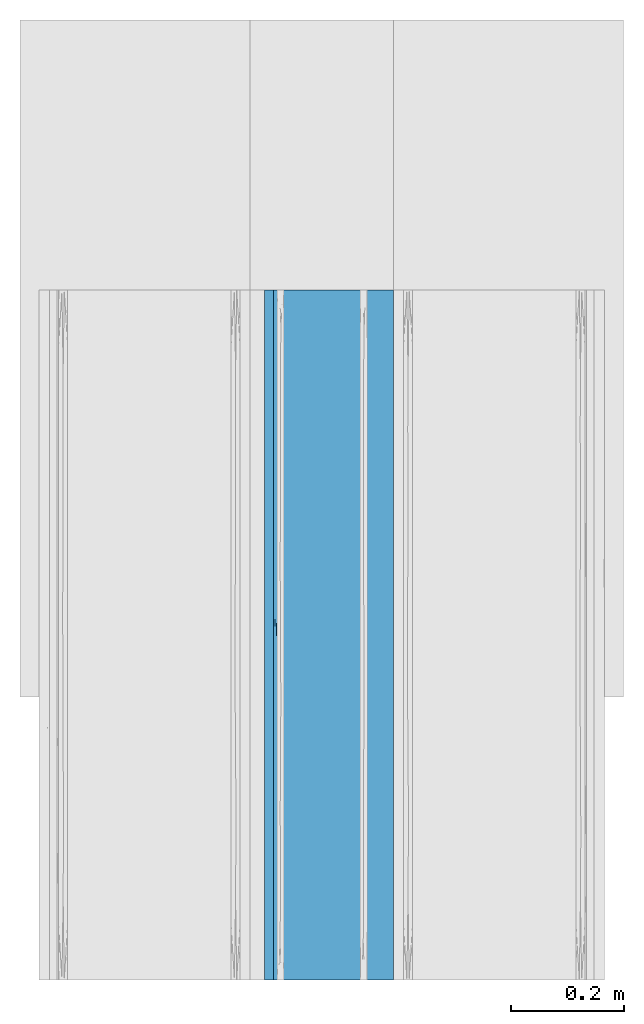
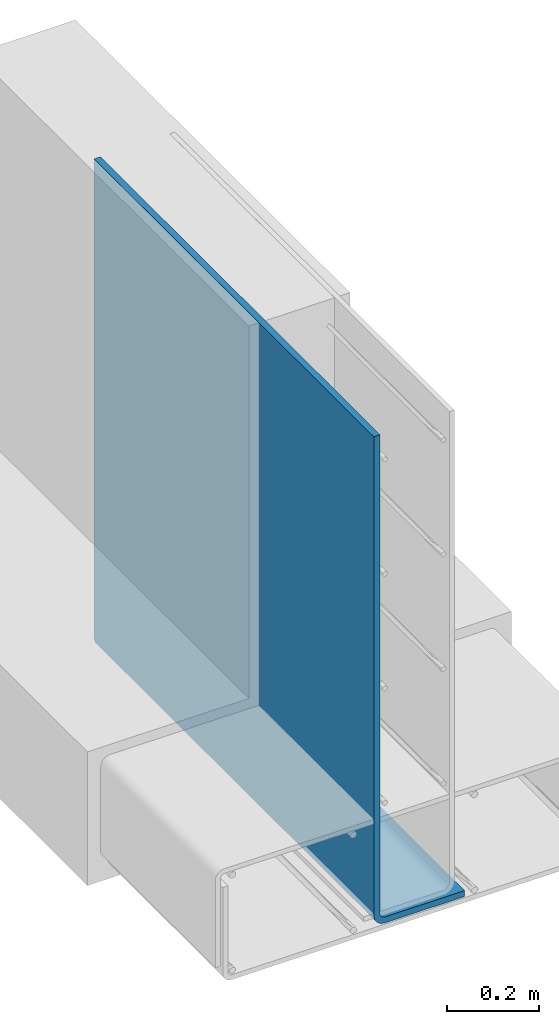
# One storey, part 2 of 10: 1 wall.
"""IFC2X3 building model written with IfcOpenShell, lengths in feet."""

from ifc_helpers import new_model, entity, si_unit, converted_unit, derived_unit, direction, frame, origin, place, context, subcontext, project, spatial, faceted_brep, material, type_object, element, save


model = new_model("IFC2X3")

# Units and contexts
model_context = context("Model", 3, precision=0.0001, world=origin(), true_north=direction((6.12303176911189e-17, 1.0)))
body_context = subcontext(model_context, "Body", "Model", "MODEL_VIEW")
ifc_project = project(units=[converted_unit("LENGTHUNIT", "FOOT", entity("IfcRatioMeasure", 0.3048), si_unit("LENGTHUNIT", "METRE"), dimensions=[1, 0, 0, 0, 0, 0, 0]), converted_unit("AREAUNIT", "SQUARE FOOT", entity("IfcRatioMeasure", 0.09290304), si_unit("AREAUNIT", "SQUARE_METRE"), dimensions=[2, 0, 0, 0, 0, 0, 0]), converted_unit("VOLUMEUNIT", "CUBIC FOOT", entity("IfcRatioMeasure", 0.028316846592), si_unit("VOLUMEUNIT", "CUBIC_METRE"), dimensions=[3, 0, 0, 0, 0, 0, 0]), converted_unit("PLANEANGLEUNIT", "DEGREE", entity("IfcRatioMeasure", 0.0174532925199433), si_unit("PLANEANGLEUNIT", "RADIAN"), dimensions=[0, 0, 0, 0, 0, 0, 0]), si_unit("MASSUNIT", "GRAM", prefix="KILO"), derived_unit("MASSDENSITYUNIT", [(si_unit("MASSUNIT", "GRAM", prefix="KILO"), 1), (si_unit("LENGTHUNIT", "METRE"), -3)]), si_unit("TIMEUNIT", "SECOND"), si_unit("FREQUENCYUNIT", "HERTZ"), si_unit("THERMODYNAMICTEMPERATUREUNIT", "DEGREE_CELSIUS"), derived_unit("THERMALTRANSMITTANCEUNIT", [(si_unit("MASSUNIT", "GRAM", prefix="KILO"), 1), (si_unit("THERMODYNAMICTEMPERATUREUNIT", "KELVIN"), -1), (si_unit("TIMEUNIT", "SECOND"), -3)]), derived_unit("VOLUMETRICFLOWRATEUNIT", [(si_unit("LENGTHUNIT", "METRE"), 3), (si_unit("TIMEUNIT", "SECOND"), -1)]), si_unit("ELECTRICCURRENTUNIT", "AMPERE"), si_unit("ELECTRICVOLTAGEUNIT", "VOLT"), si_unit("POWERUNIT", "WATT"), si_unit("FORCEUNIT", "NEWTON", prefix="KILO"), si_unit("ILLUMINANCEUNIT", "LUX"), si_unit("LUMINOUSFLUXUNIT", "LUMEN"), si_unit("LUMINOUSINTENSITYUNIT", "CANDELA"), derived_unit("USERDEFINED", [(si_unit("MASSUNIT", "GRAM", prefix="KILO"), -1), (si_unit("LENGTHUNIT", "METRE"), -2), (si_unit("TIMEUNIT", "SECOND"), 3), (si_unit("LUMINOUSFLUXUNIT", "LUMEN"), 1)]), derived_unit("LINEARVELOCITYUNIT", [(si_unit("LENGTHUNIT", "METRE"), 1), (si_unit("TIMEUNIT", "SECOND"), -1)]), si_unit("PRESSUREUNIT", "PASCAL"), derived_unit("USERDEFINED", [(si_unit("LENGTHUNIT", "METRE"), -2), (si_unit("MASSUNIT", "GRAM", prefix="KILO"), 1), (si_unit("TIMEUNIT", "SECOND"), -2)])], contexts=[model_context])

# Site, building, storey
site_placement = place(None, origin())
site = spatial("IfcSite", under=ifc_project, at=site_placement, CompositionType="ELEMENT")
building_placement = place(site_placement, origin())
building = spatial("IfcBuilding", under=site, at=building_placement, CompositionType="ELEMENT")
storey_placement = place(building_placement, frame((0.0, 0.0, 11.2604166666667)))
storey = spatial("IfcBuildingStorey", under=building, at=storey_placement, Name="2ND FLOOR", CompositionType="ELEMENT", Elevation=11.2604166666667)

# Wall
ifc_material = material()
wall_type = type_object("IfcWallType", Name="Generic Models 1", PredefinedType="NOTDEFINED", material=ifc_material)
wall_placement = place(storey_placement, frame((1429.34545536655, 0.249999999995818, 2.87899174408165), z_axis=(0.0, 0.0, 1.0), x_axis=(0.0, 1.0, 0.0)))
element("IfcWall", 1, at=wall_placement, inside=storey, type_object=wall_type, material=ifc_material, Name="Generic Models 48:Generic Models 1", ObjectType="Generic Models 48:Generic Models 1", context=body_context, shape_type="Brep", body=[
    faceted_brep([(4.0, -0.0839364688906699, 0.0535477115896743), (4.0, -0.0950595260521823, 0.05208333333354), (4.0, -0.750000000000227, 0.052083333333341), (4.0, -0.750000000000227, 0.0), (4.0, -0.0950595260521823, 0.0), (4.0, -0.0704563102915472, 0.00323907480378516), (4.0, -0.0475297630262048, 0.0127355616194791), (4.0, -0.027842290564422, 0.027842290564486), (4.0, -0.0127355616193654, 0.0475297630262546), (4.0, -0.00323907480355956, 0.0704563102916005), (4.0, 0.0, 0.0950595260523031), (4.0, 0.0, 4.27604166666677), (4.0, -0.0520833333332575, 4.27604166666677), (4.0, -0.0520833333334849, 0.0950595260523031), (4.0, -0.0535477115895446, 0.0839364688906912), (4.0, -0.0578410513996914, 0.0735714296929206), (4.0, -0.064670768751057, 0.0646707687512862), (4.0, -0.0735714296927199, 0.0578410513999188), (0.0, -0.0520833333332575, 0.095059526052296), (0.0, -0.0520833333332575, 4.27604166666676), (0.0, 0.0, 4.27604166666676), (0.0, 0.0, 0.095059526052296), (0.0, -0.00323907480355956, 0.0704563102915934), (0.0, -0.0127355616193654, 0.0475297630262475), (0.0, -0.027842290564422, 0.0278422905644788), (0.0, -0.0475297630262048, 0.012735561619472), (0.0, -0.0704563102915472, 0.00323907480377805), (0.0, -0.0950595260521823, 0.0), (0.0, -0.750000000000227, 0.0), (0.0, -0.750000000000227, 0.0520833333333339), (0.0, -0.0950595260521823, 0.0520833333335329), (0.0, -0.0839364688906699, 0.0535477115896672), (0.0, -0.0735714296927199, 0.0578410513999117), (0.0, -0.064670768751057, 0.0646707687512791), (0.0, -0.0578410513996914, 0.0735714296929135), (0.0, -0.0535477115895446, 0.0839364688906841), (3.38335830863443, 0.0, 0.0950595260523013), (2.76672867777641, 0.0, 0.0950595260522995), (2.1500990469184, 0.0, 0.0950595260522995), (1.53345735555282, 0.0, 0.0950595260522995), (0.766734708030195, 0.0, 0.095059526052296), (3.50726805026842, -0.0586818203451003, 0.00723597556192601), (3.27393777511601, -0.0371909531336314, 0.0196437335310033), (1.78353021472899, -0.00784005269451882, 0.0572563917847315), (2.14117387238675, -0.0196437335334849, 0.0371909531302208), (1.43361804854268, -0.0178613728260189, 0.0395909887384924), (3.37133042434599, -0.0196437335334849, 0.0371909531301888), (3.4751662918405, -0.00478311583447066, 0.0652856574515912), (1.1606637191544, -0.0371909531506844, 0.0196437335178299), (1.64315400905003, -0.0461789340974974, 0.0135303826530766), (1.27449515240186, -0.0633988724214305, 0.00542740845533274), (3.23328222667768, -0.0950595260521823, 0.0), (3.20256950666254, -0.0750628849159511, 0.00212703530490899), (3.07504825111212, -0.00157360909474846, 0.0778346363906177), (2.27636655169743, -0.00264474021491878, 0.0727924909575339), (0.91445812895005, -0.00186893853992842, 0.076302450257959), (0.924951748368481, -0.0775154033924537, 0.001632992062504), (0.616621456932823, -0.0950595260521823, 0.0), (2.8978709629844, -0.0586818203457824, 0.00723597556160094), (0.726062224839728, -0.0196437335423525, 0.0371909531186834), (1.47536976743383, -0.00227903482004876, 0.0743690949317362), (0.524941123404908, -0.0371909531409074, 0.0196437335254522), (0.523544479057695, -0.00603105418076666, 0.061739191577983), (2.7562521483547, -0.018206365116157, 0.0391139708455643), (2.46098355568912, -0.038044837346888, 0.0189961395572578), (2.96682787508407, -0.0072359755636171, 0.0586818203408814), (0.7465040680103, -0.0586818203571511, 0.00723597555691313), (1.23328222667768, -0.0950595260521823, 0.0), (1.72599254399019, -0.0304074615403351, 0.0253714779550513), (2.61939838635962, -0.0756580354102425, 0.00200096570387309), (1.82218751554797, -0.0633150724090683, 0.00545705311681566), (1.8499036836105, -0.0950595260521823, 0.0), (1.10212903717549, -0.00723597557271205, 0.058681820319002), (2.37080233258585, -0.00956508641502296, 0.0535021646782798), (2.35548845504497, -0.0598832576645236, 0.00674789807741227), (2.46652514054331, -0.0950595260521823, 0.0), (3.58538628570743, -0.0950595260521823, 0.05208333333354), (3.17077257141486, -0.0950595260521823, 0.0520833333335382), (2.87807960507063, -0.0950595260521823, 0.0520833333335382), (2.5853866387264, -0.0950595260521823, 0.0520833333335382), (2.29269296634424, -0.0950595260521823, 0.0520833333335382), (2.0, -0.0950595260521823, 0.0520833333335364), (1.70730703365578, -0.0950595260521823, 0.0520833333335382), (1.41461336127362, -0.0950595260521823, 0.0520833333335347), (1.12192039492938, -0.0950595260521823, 0.0520833333335364), (0.829227428585153, -0.0950595260521823, 0.0520833333335347), (0.414613714292581, -0.0950595260524096, 0.0520833333335329), (0.343508341855533, -0.06096421998609, 0.0688972775850552), (0.24642137997777, -0.0553547012057152, 0.0786132491327418), (2.95385912061898, -0.0671572125691, 0.0623729226361025), (2.74421780120822, -0.0756354022480537, 0.0567234261587952), (3.09787157995616, -0.0779605053130581, 0.0556314062598702), (0.257111616052899, -0.0872671962911227, 0.052795679356878), (2.52465034980815, -0.0790851264434878, 0.0551625124079091), (2.33368133182246, -0.0735031881267787, 0.0578805341906605), (2.29269299774973, -0.081677182318117, 0.0542200106684696), (0.346070907250912, -0.0786132490784439, 0.0553547012283602), (2.73173249481835, -0.0856930366287543, 0.0531164453776292), (2.48423128693805, -0.0871304496311041, 0.0528211206881188), (0.4997990553644, -0.0528710843739191, 0.0868687672740833), (0.248516744073481, -0.052728189989466, 0.0876425773712306), (3.80586512939922, -0.0553547012129911, 0.0786132491152109), (3.74780526621007, -0.0527566628134082, 0.0874818679445095), (3.58538581327789, -0.0520833333334849, 0.0950595260523013), (3.49313826499759, -0.0528751288923104, 0.0868479624460363), (0.414614186722129, -0.0520833333334849, 0.0950595260522977), (3.65649165725621, -0.068897277555152, 0.0609642200091614), (3.71348541599941, -0.0609642200031431, 0.0688972775628098), (3.30751289932597, -0.0691599293538729, 0.060764278109378), (3.45927734759776, -0.0594241450330628, 0.0710371872773639), (3.20506927914898, -0.0609642200013241, 0.0688972775652505), (3.75357861923602, -0.0786132491082299, 0.0553547012159452), (0.250219458519215, -0.0688972775394632, 0.0609642200212246), (2.89455993463712, -0.0599559398117435, 0.0702665558055084), (3.75148325519992, -0.0876425773483334, 0.0527281899934824), (3.10938631631815, -0.0544012868585924, 0.0811361383081515), (0.54431608530737, -0.0856559896490126, 0.053124735678276), (1.11334942453932, -0.0549875058245561, 0.0795293510541804), (1.45114901067811, -0.055454032351463, 0.0783754615197712), (1.41892933789295, -0.0527407089648477, 0.0875714781808323), (3.52808113600233, -0.0876043389177994, 0.0527349076205557), (0.541386240932319, -0.0553547011959381, 0.0786132491562626), (0.805493389358163, -0.0534599123263888, 0.0842694714436831), (0.732200476778303, -0.0628856438781895, 0.0665675193408237), (3.33830627388194, -0.0543801832284316, 0.081197916909483), (1.95828153209831, -0.0552608766715821, 0.0788416147168505), (2.22557450496979, -0.0543799459010188, 0.0811986134085618), (1.9606536364037, -0.0528456510983233, 0.0870008721962403), (1.56096050227781, -0.0851551220914644, 0.0532402012994471), (0.57662606195596, -0.0760418240306535, 0.0565201935409547), (0.548364641454425, -0.0688972775158163, 0.0609642200392031), (3.02442549301749, -0.0868657433179578, 0.0528716715784903), (1.73105420255024, -0.0535178232776161, 0.0840486191331156), (3.45861375743398, -0.078613249105274, 0.0553547012172491), (3.30695394079733, -0.086519455238431, 0.0529404053219817), (3.55294395442797, -0.0553547012120816, 0.0786132491174563), (0.808282176293639, -0.0571481321976535, 0.0748189885939929), (0.975732396537778, -0.0702672708400769, 0.059955434807863), (0.975574506197251, -0.0869005017987092, 0.0528649355953252), (0.784056237130786, -0.0801656860983258, 0.0547466661683131), (1.22270559805292, -0.0815297955959977, 0.0542686013951901), (1.00727074968171, -0.0795123348625566, 0.0549941047177551), (1.7073070019562, -0.0757839476964364, 0.0566485221647639), (1.45058811261653, -0.0773733066776003, 0.0558912891142391), (1.88559123638505, -0.0846079880495836, 0.0533735752537208), (2.08573983713143, -0.0710323456626156, 0.0594274093158216), (1.74470681603436, -0.0653764161586423, 0.0639811392272449), (2.66861517219364, -0.0561484930942697, 0.0768143991756585), (2.50498577391431, -0.0646618362679874, 0.0646797038609428), (2.60365350016018, -0.0529044639536096, 0.0866986720253351), (2.87766484896829, -0.0530354350771631, 0.0860634759016108), (2.70847635885235, -0.068417706891978, 0.0613376249725981), (2.46068863060826, -0.0546557652439787, 0.080414074432154), (2.41461418672213, -0.0520833333334849, 0.0950595260522995), (2.03653500690591, -0.0610243254272973, 0.0688191324001401), (2.38388321984759, -0.0584062206412455, 0.0726209801310684), (0.829228373444251, -0.0520833333334849, 0.095059526052296), (1.03653667025295, -0.0520833333334849, 0.0950595260522977), (1.01938636295128, -0.0609642199488007, 0.06889727763377), (1.14018850857098, -0.0527474492546389, 0.0875334847507396), (1.48724211501289, -0.0602209726457659, 0.0698954974172068), (1.40042308287624, -0.0664782840467524, 0.0629648887117344), (1.24384256016637, -0.0520833333334849, 0.0950595260522977), (1.25767826442176, -0.0618047567277245, 0.0678368616387957), (1.17376868854571, -0.0669068622153191, 0.0625882978726953), (1.74354393160202, -0.0579399859857404, 0.0734009737954722), (1.22276049636679, -0.0731446832442089, 0.0580907175063849), (2.8938170462308, -0.055424927612421, 0.0784447209940442), (3.17077162655576, -0.0520833333334849, 0.0950595260523031), (2.79269411008658, -0.0520833333337123, 0.0950595260523031), (1.65845674688849, -0.0520833333334849, 0.0950595260522995), (2.03653426335767, -0.0520833333332575, 0.0950595260522995), (2.2377648516676, -0.0651019592553439, 0.0642456114645995)], [[[0, 1, 2, 3, 4, 5, 6, 7, 8, 9, 10, 11, 12, 13, 14, 15, 16, 17]], [[18, 19, 20, 21, 22, 23, 24, 25, 26, 27, 28, 29, 30, 31, 32, 33, 34, 35]], [[20, 19, 12, 11]], [[21, 20, 11, 10, 36, 37, 38, 39, 40]], [[41, 42, 6]], [[43, 44, 45]], [[6, 42, 7]], [[6, 5, 41]], [[46, 8, 7]], [[8, 46, 47]], [[48, 49, 50]], [[51, 52, 4]], [[22, 21, 40]], [[36, 10, 9]], [[37, 53, 54]], [[39, 55, 40]], [[26, 56, 57]], [[52, 58, 41]], [[45, 48, 59]], [[60, 38, 54]], [[24, 61, 25]], [[59, 23, 62]], [[44, 63, 64]], [[53, 47, 65]], [[56, 26, 66]], [[25, 61, 66]], [[46, 7, 42]], [[25, 66, 26]], [[55, 62, 22]], [[50, 67, 56]], [[23, 59, 24]], [[68, 48, 45]], [[36, 53, 37]], [[69, 58, 52]], [[70, 71, 50]], [[45, 59, 72]], [[55, 39, 60]], [[61, 59, 48]], [[64, 42, 58]], [[51, 69, 52]], [[44, 73, 63]], [[69, 74, 58]], [[68, 49, 48]], [[42, 64, 63]], [[47, 46, 65]], [[57, 56, 67]], [[57, 27, 26]], [[50, 56, 66]], [[47, 36, 9]], [[54, 53, 65]], [[43, 73, 44]], [[54, 43, 60]], [[36, 47, 53]], [[8, 47, 9]], [[48, 50, 66]], [[69, 71, 70]], [[59, 61, 24]], [[66, 61, 48]], [[42, 41, 58]], [[43, 45, 72]], [[45, 44, 68]], [[60, 43, 72]], [[43, 54, 73]], [[60, 72, 55]], [[62, 55, 72]], [[22, 40, 55]], [[59, 62, 72]], [[23, 22, 62]], [[54, 65, 73]], [[63, 65, 46]], [[65, 63, 73]], [[63, 46, 42]], [[44, 64, 68]], [[64, 74, 49]], [[64, 49, 68]], [[50, 49, 70]], [[5, 4, 52]], [[5, 52, 41]], [[69, 51, 75, 71]], [[38, 60, 39]], [[74, 69, 70]], [[49, 74, 70]], [[64, 58, 74]], [[67, 50, 71]], [[38, 37, 54]], [[28, 27, 57, 67, 71, 75, 51, 4, 3]], [[29, 28, 3, 2]], [[29, 2, 1, 76, 77, 78, 79, 80, 81, 82, 83, 84, 85, 86, 30]], [[34, 87, 88]], [[89, 90, 91]], [[92, 31, 30]], [[93, 94, 95]], [[33, 87, 34]], [[32, 31, 96]], [[97, 93, 98]], [[99, 100, 88]], [[14, 101, 15]], [[102, 103, 104]], [[105, 18, 100]], [[16, 106, 17]], [[107, 16, 15]], [[108, 109, 110]], [[106, 111, 17]], [[111, 0, 17]], [[89, 108, 110]], [[35, 34, 88]], [[32, 112, 33]], [[113, 89, 110]], [[16, 107, 106]], [[114, 76, 1]], [[115, 113, 110]], [[86, 85, 116]], [[117, 118, 119]], [[120, 114, 111]], [[99, 121, 122]], [[123, 121, 87]], [[115, 110, 124]], [[102, 101, 14]], [[96, 112, 32]], [[96, 92, 116]], [[125, 126, 127]], [[82, 128, 83]], [[129, 130, 96]], [[96, 31, 92]], [[131, 91, 97]], [[119, 118, 132]], [[133, 106, 108]], [[77, 76, 134]], [[135, 109, 107]], [[123, 136, 121]], [[121, 99, 88]], [[130, 87, 112]], [[123, 130, 137]], [[85, 84, 138]], [[129, 139, 137]], [[140, 141, 138]], [[128, 142, 143]], [[109, 108, 106]], [[13, 102, 14]], [[135, 107, 101]], [[121, 88, 87]], [[33, 112, 87]], [[130, 112, 96]], [[133, 111, 106]], [[133, 108, 91]], [[89, 91, 108]], [[134, 131, 77]], [[78, 77, 131]], [[144, 82, 81]], [[80, 98, 95]], [[145, 146, 142]], [[147, 148, 113]], [[149, 147, 150]], [[90, 89, 151]], [[152, 149, 153]], [[151, 94, 93]], [[126, 154, 155]], [[79, 97, 98]], [[78, 97, 79]], [[90, 97, 91]], [[78, 131, 97]], [[133, 91, 134]], [[131, 134, 91]], [[133, 120, 111]], [[0, 111, 114]], [[0, 114, 1]], [[120, 76, 114]], [[35, 88, 100]], [[35, 100, 18]], [[99, 105, 100]], [[99, 156, 105]], [[156, 99, 122]], [[157, 156, 122]], [[122, 121, 136]], [[158, 117, 136]], [[117, 119, 159]], [[160, 161, 146]], [[122, 136, 117]], [[123, 158, 136]], [[159, 162, 157]], [[163, 160, 118]], [[137, 158, 123]], [[130, 123, 87]], [[164, 163, 158]], [[116, 85, 138]], [[163, 118, 117]], [[132, 118, 165]], [[143, 166, 140]], [[144, 128, 82]], [[151, 89, 113]], [[119, 162, 159]], [[147, 167, 150]], [[124, 104, 168]], [[153, 149, 169]], [[150, 115, 168]], [[122, 159, 157]], [[117, 159, 122]], [[119, 170, 162]], [[170, 119, 132]], [[126, 153, 171]], [[165, 125, 132]], [[127, 171, 170]], [[147, 155, 148]], [[125, 165, 154]], [[154, 165, 146]], [[165, 118, 160]], [[154, 146, 145]], [[146, 161, 142]], [[154, 145, 172]], [[144, 95, 145]], [[165, 160, 146]], [[161, 160, 163]], [[164, 166, 161]], [[158, 163, 117]], [[132, 125, 127]], [[126, 125, 154]], [[132, 127, 170]], [[171, 127, 126]], [[120, 134, 76]], [[134, 120, 133]], [[95, 81, 80]], [[95, 98, 93]], [[80, 79, 98]], [[94, 145, 95]], [[90, 93, 97]], [[145, 94, 172]], [[151, 148, 94]], [[169, 149, 150]], [[147, 149, 152]], [[169, 150, 168]], [[167, 115, 150]], [[167, 113, 115]], [[167, 147, 113]], [[15, 101, 107]], [[102, 104, 135]], [[101, 102, 135]], [[103, 102, 13]], [[135, 104, 124]], [[104, 103, 168]], [[109, 135, 124]], [[115, 124, 168]], [[116, 129, 96]], [[86, 92, 30]], [[138, 139, 116]], [[116, 92, 86]], [[130, 129, 137]], [[139, 129, 116]], [[128, 143, 140]], [[83, 128, 140]], [[144, 142, 128]], [[142, 144, 145]], [[144, 81, 95]], [[166, 141, 140]], [[143, 142, 161]], [[163, 164, 161]], [[166, 143, 161]], [[164, 137, 166]], [[137, 164, 158]], [[106, 107, 109]], [[110, 109, 124]], [[93, 90, 151]], [[148, 151, 113]], [[84, 83, 140]], [[139, 138, 141]], [[138, 84, 140]], [[141, 137, 139]], [[137, 141, 166]], [[172, 148, 155]], [[126, 155, 152]], [[154, 172, 155]], [[148, 172, 94]], [[147, 152, 155]], [[126, 152, 153]], [[19, 18, 105, 156, 157, 162, 170, 171, 153, 169, 168, 103, 13, 12]]]),
])

save(model, "model.ifc")
